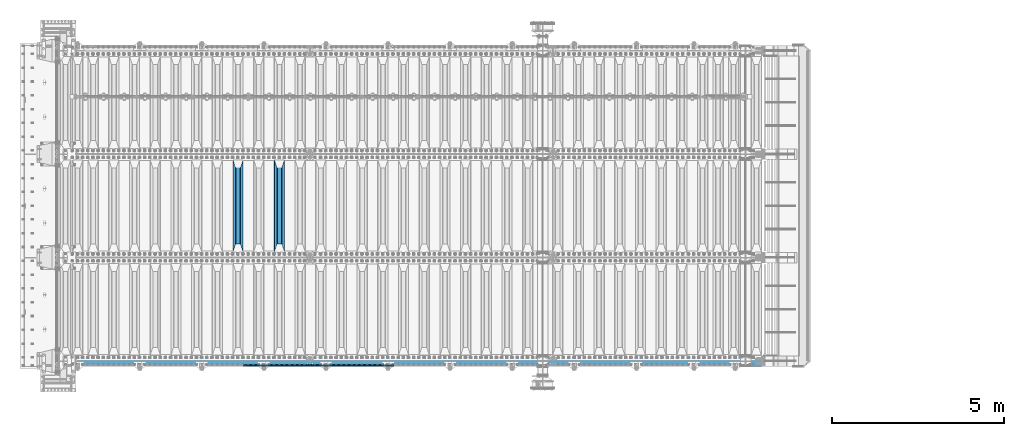
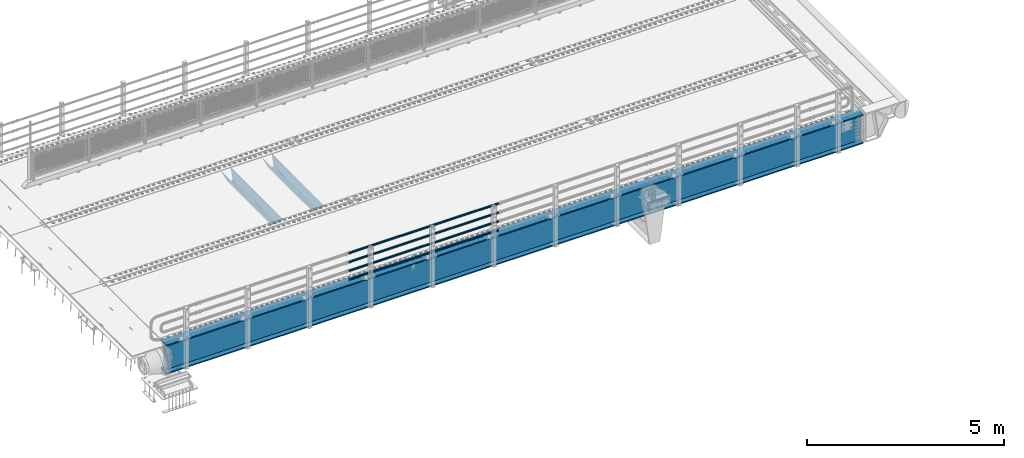
# One storey, part 120 of 270: 7 beams.
"""IFC2X3 building model written with IfcOpenShell, lengths in millimetres."""

from ifc_helpers import new_model, si_unit, frame, origin_with_axes, place, context, subcontext, project, spatial, faceted_brep, material, type_object, element, save


model = new_model("IFC2X3")

# Units and contexts
model_context = context("Model", 3, precision=1e-05, world=origin_with_axes())
body_context = subcontext(model_context, "Body", "Model", "MODEL_VIEW")
ifc_project = project(units=[si_unit("LENGTHUNIT", "METRE", prefix="MILLI"), si_unit("AREAUNIT", "SQUARE_METRE"), si_unit("VOLUMEUNIT", "CUBIC_METRE"), si_unit("MASSUNIT", "GRAM", prefix="KILO"), si_unit("TIMEUNIT", "SECOND"), si_unit("PLANEANGLEUNIT", "RADIAN"), si_unit("SOLIDANGLEUNIT", "STERADIAN"), si_unit("THERMODYNAMICTEMPERATUREUNIT", "DEGREE_CELSIUS"), si_unit("LUMINOUSINTENSITYUNIT", "LUMEN")], contexts=[model_context])

# Site, building, storey
site_placement = place(None, origin_with_axes())
site = spatial("IfcSite", under=ifc_project, at=site_placement, CompositionType="ELEMENT")
building_placement = place(site_placement, origin_with_axes())
building = spatial("IfcBuilding", under=site, at=building_placement, Name="Standard", CompositionType="ELEMENT")
storey_placement = place(building_placement, origin_with_axes())
storey = spatial("IfcBuildingStorey", under=building, at=storey_placement, Name="Undefined", CompositionType="ELEMENT", Elevation=0.0)

# Beams
ifc_material_1 = material()
beam_type_1 = type_object("IfcBeamType", PredefinedType="NOTDEFINED")
beam_1_placement = place(storey_placement, frame((9727.99999999987, -24129.8499999999, 149.849999999726), z_axis=(0.0, 0.0, -1.0), x_axis=(-1.0, 0.0, 0.0)))
element("IfcBeam", 1, at=beam_1_placement, inside=storey, type_object=beam_type_1, material=ifc_material_1, context=body_context, shape_type="Brep", body=[
    faceted_brep([(0.0, -26.5499999999993, 0.0), (0.0, -24.5290015881747, 10.1602451292931), (4384.00249699992, -24.5290015881747, 10.1602451292931), (4384.00249699992, -26.5499999999993, 0.0), (0.0, -18.7736850405036, 18.7736850405028), (4384.00249699992, -18.7736850405036, 18.7736850405028), (0.0, -10.1602451292929, 24.5290015881747), (4384.00249699992, -10.1602451292929, 24.5290015881747), (0.0, 0.0, 26.55), (4384.00249699992, 0.0, 26.55), (0.0, 10.1602451292929, 24.5290015881747), (4384.00249699992, 10.1602451292929, 24.5290015881747), (0.0, 18.7736850405036, 18.7736850405028), (4384.00249699992, 18.7736850405036, 18.7736850405028), (0.0, 24.5290015881747, 10.1602451292931), (4384.00249699992, 24.5290015881747, 10.1602451292931), (0.0, 26.5499999999993, 0.0), (4384.00249699992, 26.5499999999993, 0.0), (0.0, 24.5290015881747, -10.1602451292931), (4384.00249699992, 24.5290015881747, -10.1602451292931), (0.0, 18.7736850405036, -18.7736850405028), (4384.00249699992, 18.7736850405036, -18.7736850405028), (0.0, 10.1602451292929, -24.5290015881747), (4384.00249699992, 10.1602451292929, -24.5290015881747), (0.0, 0.0, -26.55), (4384.00249699992, 0.0, -26.55), (0.0, -10.1602451292929, -24.5290015881747), (4384.00249699992, -10.1602451292929, -24.5290015881747), (0.0, -18.7736850405036, -18.7736850405028), (4384.00249699992, -18.7736850405036, -18.7736850405028), (0.0, -24.5290015881747, -10.1602451292931), (4384.00249699992, -24.5290015881747, -10.1602451292931), (0.0, -30.1499999999996, 0.0), (0.0, -27.8549679052157, -11.5379054858058), (4384.00249699992, -27.8549679052157, -11.5379054858075), (4384.00249699992, -30.1499999999996, 0.0), (0.0, -21.3192694527752, -21.3192694527752), (4384.00249699992, -21.3192694527752, -21.3192694527744), (0.0, -11.5379054858076, -27.8549679052157), (4384.00249699992, -11.5379054858076, -27.8549679052153), (0.0, 0.0, -30.1500000000015), (4384.00249699992, 0.0, -30.15), (0.0, 11.5379054858076, -27.8549679052157), (4384.00249699992, 11.5379054858076, -27.8549679052153), (0.0, 21.3192694527752, -21.3192694527752), (4384.00249699992, 21.3192694527752, -21.3192694527744), (0.0, 27.8549679052157, -11.5379054858058), (4384.00249699992, 27.8549679052157, -11.5379054858074), (0.0, 30.1499999999996, 0.0), (4384.00249699992, 30.1499999999996, 0.0), (0.0, 27.8549679052157, 11.5379054858058), (4384.00249699992, 27.8549679052157, 11.5379054858075), (0.0, 21.3192694527752, 21.3192694527752), (4384.00249699992, 21.3192694527752, 21.3192694527744), (0.0, 11.5379054858076, 27.8549679052157), (4384.00249699992, 11.5379054858076, 27.8549679052153), (0.0, 0.0, 30.1500000000015), (4384.00249699992, 0.0, 30.15), (0.0, -11.5379054858076, 27.8549679052157), (4384.00249699992, -11.5379054858076, 27.8549679052153), (0.0, -21.3192694527752, 21.3192694527752), (4384.00249699992, -21.3192694527752, 21.3192694527744), (0.0, -27.8549679052157, 11.5379054858058), (4384.00249699992, -27.8549679052157, 11.5379054858075)], [[[0, 1, 2, 3]], [[1, 4, 5, 2]], [[4, 6, 7, 5]], [[6, 8, 9, 7]], [[8, 10, 11, 9]], [[10, 12, 13, 11]], [[12, 14, 15, 13]], [[14, 16, 17, 15]], [[16, 18, 19, 17]], [[18, 20, 21, 19]], [[20, 22, 23, 21]], [[22, 24, 25, 23]], [[24, 26, 27, 25]], [[26, 28, 29, 27]], [[28, 30, 31, 29]], [[30, 0, 3, 31]], [[32, 33, 34, 35]], [[33, 36, 37, 34]], [[36, 38, 39, 37]], [[38, 40, 41, 39]], [[40, 42, 43, 41]], [[42, 44, 45, 43]], [[44, 46, 47, 45]], [[46, 48, 49, 47]], [[48, 50, 51, 49]], [[50, 52, 53, 51]], [[52, 54, 55, 53]], [[54, 56, 57, 55]], [[56, 58, 59, 57]], [[58, 60, 61, 59]], [[60, 62, 63, 61]], [[62, 32, 35, 63]], [[37, 39, 41, 43, 45, 47, 49, 51, 53, 55, 57, 59, 61, 63, 35, 34], [5, 7, 9, 11, 13, 15, 17, 19, 21, 23, 25, 27, 29, 31, 3, 2]], [[62, 60, 58, 56, 54, 52, 50, 48, 46, 44, 42, 40, 38, 36, 33, 32], [30, 28, 26, 24, 22, 20, 18, 16, 14, 12, 10, 8, 6, 4, 1, 0]]]),
])
beam_2_placement = place(storey_placement, frame((9727.99999999987, -24129.8499999999, 420.149999999729), z_axis=(0.0, 0.0, -1.0), x_axis=(-1.0, 0.0, 0.0)))
element("IfcBeam", 2, at=beam_2_placement, inside=storey, type_object=beam_type_1, material=ifc_material_1, context=body_context, shape_type="Brep", body=[
    faceted_brep([(0.0, -26.5499999999993, 0.0), (0.0, -24.5290015881747, 10.1602451292931), (4384.00249699992, -24.5290015881747, 10.1602451292931), (4384.00249699992, -26.5499999999993, 0.0), (0.0, -18.7736850405036, 18.7736850405028), (4384.00249699992, -18.7736850405036, 18.7736850405028), (0.0, -10.1602451292929, 24.5290015881747), (4384.00249699992, -10.1602451292929, 24.5290015881747), (0.0, 0.0, 26.55), (4384.00249699992, 0.0, 26.55), (0.0, 10.1602451292929, 24.5290015881747), (4384.00249699992, 10.1602451292929, 24.5290015881747), (0.0, 18.7736850405036, 18.7736850405028), (4384.00249699992, 18.7736850405036, 18.7736850405028), (0.0, 24.5290015881747, 10.1602451292931), (4384.00249699992, 24.5290015881747, 10.1602451292931), (0.0, 26.5499999999993, 0.0), (4384.00249699992, 26.5499999999993, 0.0), (0.0, 24.5290015881747, -10.1602451292931), (4384.00249699992, 24.5290015881747, -10.1602451292931), (0.0, 18.7736850405036, -18.7736850405028), (4384.00249699992, 18.7736850405036, -18.7736850405028), (0.0, 10.1602451292929, -24.5290015881747), (4384.00249699992, 10.1602451292929, -24.5290015881747), (0.0, 0.0, -26.55), (4384.00249699992, 0.0, -26.55), (0.0, -10.1602451292929, -24.5290015881747), (4384.00249699992, -10.1602451292929, -24.5290015881747), (0.0, -18.7736850405036, -18.7736850405028), (4384.00249699992, -18.7736850405036, -18.7736850405028), (0.0, -24.5290015881747, -10.1602451292931), (4384.00249699992, -24.5290015881747, -10.1602451292931), (0.0, -30.1499999999996, 0.0), (0.0, -27.8549679052157, -11.5379054858058), (4384.00249699992, -27.8549679052157, -11.5379054858075), (4384.00249699992, -30.1499999999996, 0.0), (0.0, -21.3192694527752, -21.3192694527752), (4384.00249699992, -21.3192694527752, -21.3192694527744), (0.0, -11.5379054858076, -27.8549679052157), (4384.00249699992, -11.5379054858076, -27.8549679052153), (0.0, 0.0, -30.1500000000015), (4384.00249699992, 0.0, -30.15), (0.0, 11.5379054858076, -27.8549679052157), (4384.00249699992, 11.5379054858076, -27.8549679052153), (0.0, 21.3192694527752, -21.3192694527752), (4384.00249699992, 21.3192694527752, -21.3192694527744), (0.0, 27.8549679052157, -11.5379054858058), (4384.00249699992, 27.8549679052157, -11.5379054858074), (0.0, 30.1499999999996, 0.0), (4384.00249699992, 30.1499999999996, 0.0), (0.0, 27.8549679052157, 11.5379054858058), (4384.00249699992, 27.8549679052157, 11.5379054858075), (0.0, 21.3192694527752, 21.3192694527752), (4384.00249699992, 21.3192694527752, 21.3192694527744), (0.0, 11.5379054858076, 27.8549679052157), (4384.00249699992, 11.5379054858076, 27.8549679052153), (0.0, 0.0, 30.1500000000015), (4384.00249699992, 0.0, 30.15), (0.0, -11.5379054858076, 27.8549679052157), (4384.00249699992, -11.5379054858076, 27.8549679052153), (0.0, -21.3192694527752, 21.3192694527752), (4384.00249699992, -21.3192694527752, 21.3192694527744), (0.0, -27.8549679052157, 11.5379054858058), (4384.00249699992, -27.8549679052157, 11.5379054858075)], [[[0, 1, 2, 3]], [[1, 4, 5, 2]], [[4, 6, 7, 5]], [[6, 8, 9, 7]], [[8, 10, 11, 9]], [[10, 12, 13, 11]], [[12, 14, 15, 13]], [[14, 16, 17, 15]], [[16, 18, 19, 17]], [[18, 20, 21, 19]], [[20, 22, 23, 21]], [[22, 24, 25, 23]], [[24, 26, 27, 25]], [[26, 28, 29, 27]], [[28, 30, 31, 29]], [[30, 0, 3, 31]], [[32, 33, 34, 35]], [[33, 36, 37, 34]], [[36, 38, 39, 37]], [[38, 40, 41, 39]], [[40, 42, 43, 41]], [[42, 44, 45, 43]], [[44, 46, 47, 45]], [[46, 48, 49, 47]], [[48, 50, 51, 49]], [[50, 52, 53, 51]], [[52, 54, 55, 53]], [[54, 56, 57, 55]], [[56, 58, 59, 57]], [[58, 60, 61, 59]], [[60, 62, 63, 61]], [[62, 32, 35, 63]], [[37, 39, 41, 43, 45, 47, 49, 51, 53, 55, 57, 59, 61, 63, 35, 34], [5, 7, 9, 11, 13, 15, 17, 19, 21, 23, 25, 27, 29, 31, 3, 2]], [[62, 60, 58, 56, 54, 52, 50, 48, 46, 44, 42, 40, 38, 36, 33, 32], [30, 28, 26, 24, 22, 20, 18, 16, 14, 12, 10, 8, 6, 4, 1, 0]]]),
])
beam_3_placement = place(storey_placement, frame((9727.99999999987, -24129.8499999999, 969.849999999726), z_axis=(0.0, 0.0, -1.0), x_axis=(-1.0, 0.0, 0.0)))
element("IfcBeam", 3, at=beam_3_placement, inside=storey, type_object=beam_type_1, material=ifc_material_1, context=body_context, shape_type="Brep", body=[
    faceted_brep([(0.0, -26.5499999999993, 0.0), (0.0, -24.5290015881747, 10.1602451292931), (4384.00249699992, -24.5290015881747, 10.1602451292931), (4384.00249699992, -26.5499999999993, 0.0), (0.0, -18.7736850405036, 18.7736850405028), (4384.00249699992, -18.7736850405036, 18.7736850405028), (0.0, -10.1602451292929, 24.5290015881747), (4384.00249699992, -10.1602451292929, 24.5290015881747), (0.0, 0.0, 26.55), (4384.00249699992, 0.0, 26.55), (0.0, 10.1602451292929, 24.5290015881747), (4384.00249699992, 10.1602451292929, 24.5290015881747), (0.0, 18.7736850405036, 18.7736850405028), (4384.00249699992, 18.7736850405036, 18.7736850405028), (0.0, 24.5290015881747, 10.1602451292931), (4384.00249699992, 24.5290015881747, 10.1602451292931), (0.0, 26.5499999999993, 0.0), (4384.00249699992, 26.5499999999993, 0.0), (0.0, 24.5290015881747, -10.1602451292931), (4384.00249699992, 24.5290015881747, -10.1602451292931), (0.0, 18.7736850405036, -18.7736850405028), (4384.00249699992, 18.7736850405036, -18.7736850405028), (0.0, 10.1602451292929, -24.5290015881747), (4384.00249699992, 10.1602451292929, -24.5290015881747), (0.0, 0.0, -26.55), (4384.00249699992, 0.0, -26.55), (0.0, -10.1602451292929, -24.5290015881747), (4384.00249699992, -10.1602451292929, -24.5290015881747), (0.0, -18.7736850405036, -18.7736850405028), (4384.00249699992, -18.7736850405036, -18.7736850405028), (0.0, -24.5290015881747, -10.1602451292931), (4384.00249699992, -24.5290015881747, -10.1602451292931), (0.0, -30.1499999999996, 0.0), (0.0, -27.8549679052157, -11.5379054858058), (4384.00249699992, -27.8549679052157, -11.5379054858075), (4384.00249699992, -30.1499999999996, 0.0), (0.0, -21.3192694527752, -21.3192694527752), (4384.00249699992, -21.3192694527752, -21.3192694527744), (0.0, -11.5379054858076, -27.8549679052157), (4384.00249699992, -11.5379054858076, -27.8549679052153), (0.0, 0.0, -30.1500000000015), (4384.00249699992, 0.0, -30.15), (0.0, 11.5379054858076, -27.8549679052157), (4384.00249699992, 11.5379054858076, -27.8549679052153), (0.0, 21.3192694527752, -21.3192694527752), (4384.00249699992, 21.3192694527752, -21.3192694527744), (0.0, 27.8549679052157, -11.5379054858058), (4384.00249699992, 27.8549679052157, -11.5379054858074), (0.0, 30.1499999999996, 0.0), (4384.00249699992, 30.1499999999996, 0.0), (0.0, 27.8549679052157, 11.5379054858058), (4384.00249699992, 27.8549679052157, 11.5379054858075), (0.0, 21.3192694527752, 21.3192694527752), (4384.00249699992, 21.3192694527752, 21.3192694527744), (0.0, 11.5379054858076, 27.8549679052157), (4384.00249699992, 11.5379054858076, 27.8549679052153), (0.0, 0.0, 30.1500000000015), (4384.00249699992, 0.0, 30.15), (0.0, -11.5379054858076, 27.8549679052157), (4384.00249699992, -11.5379054858076, 27.8549679052153), (0.0, -21.3192694527752, 21.3192694527752), (4384.00249699992, -21.3192694527752, 21.3192694527744), (0.0, -27.8549679052157, 11.5379054858058), (4384.00249699992, -27.8549679052157, 11.5379054858075)], [[[0, 1, 2, 3]], [[1, 4, 5, 2]], [[4, 6, 7, 5]], [[6, 8, 9, 7]], [[8, 10, 11, 9]], [[10, 12, 13, 11]], [[12, 14, 15, 13]], [[14, 16, 17, 15]], [[16, 18, 19, 17]], [[18, 20, 21, 19]], [[20, 22, 23, 21]], [[22, 24, 25, 23]], [[24, 26, 27, 25]], [[26, 28, 29, 27]], [[28, 30, 31, 29]], [[30, 0, 3, 31]], [[32, 33, 34, 35]], [[33, 36, 37, 34]], [[36, 38, 39, 37]], [[38, 40, 41, 39]], [[40, 42, 43, 41]], [[42, 44, 45, 43]], [[44, 46, 47, 45]], [[46, 48, 49, 47]], [[48, 50, 51, 49]], [[50, 52, 53, 51]], [[52, 54, 55, 53]], [[54, 56, 57, 55]], [[56, 58, 59, 57]], [[58, 60, 61, 59]], [[60, 62, 63, 61]], [[62, 32, 35, 63]], [[37, 39, 41, 43, 45, 47, 49, 51, 53, 55, 57, 59, 61, 63, 35, 34], [5, 7, 9, 11, 13, 15, 17, 19, 21, 23, 25, 27, 29, 31, 3, 2]], [[62, 60, 58, 56, 54, 52, 50, 48, 46, 44, 42, 40, 38, 36, 33, 32], [30, 28, 26, 24, 22, 20, 18, 16, 14, 12, 10, 8, 6, 4, 1, 0]]]),
])
beam_4_placement = place(storey_placement, frame((9727.99999999987, -24129.8499999999, 689.849999999726), z_axis=(0.0, 0.0, -1.0), x_axis=(-1.0, 0.0, 0.0)))
element("IfcBeam", 4, at=beam_4_placement, inside=storey, type_object=beam_type_1, material=ifc_material_1, context=body_context, shape_type="Brep", body=[
    faceted_brep([(0.0, -26.5499999999993, 0.0), (0.0, -24.5290015881747, 10.1602451292931), (4384.00249699992, -24.5290015881747, 10.1602451292931), (4384.00249699992, -26.5499999999993, 0.0), (0.0, -18.7736850405036, 18.7736850405028), (4384.00249699992, -18.7736850405036, 18.7736850405028), (0.0, -10.1602451292929, 24.5290015881747), (4384.00249699992, -10.1602451292929, 24.5290015881747), (0.0, 0.0, 26.55), (4384.00249699992, 0.0, 26.55), (0.0, 10.1602451292929, 24.5290015881747), (4384.00249699992, 10.1602451292929, 24.5290015881747), (0.0, 18.7736850405036, 18.7736850405028), (4384.00249699992, 18.7736850405036, 18.7736850405028), (0.0, 24.5290015881747, 10.1602451292931), (4384.00249699992, 24.5290015881747, 10.1602451292931), (0.0, 26.5499999999993, 0.0), (4384.00249699992, 26.5499999999993, 0.0), (0.0, 24.5290015881747, -10.1602451292931), (4384.00249699992, 24.5290015881747, -10.1602451292931), (0.0, 18.7736850405036, -18.7736850405028), (4384.00249699992, 18.7736850405036, -18.7736850405028), (0.0, 10.1602451292929, -24.5290015881747), (4384.00249699992, 10.1602451292929, -24.5290015881747), (0.0, 0.0, -26.55), (4384.00249699992, 0.0, -26.55), (0.0, -10.1602451292929, -24.5290015881747), (4384.00249699992, -10.1602451292929, -24.5290015881747), (0.0, -18.7736850405036, -18.7736850405028), (4384.00249699992, -18.7736850405036, -18.7736850405028), (0.0, -24.5290015881747, -10.1602451292931), (4384.00249699992, -24.5290015881747, -10.1602451292931), (0.0, -30.1499999999996, 0.0), (0.0, -27.8549679052157, -11.5379054858058), (4384.00249699992, -27.8549679052157, -11.5379054858075), (4384.00249699992, -30.1499999999996, 0.0), (0.0, -21.3192694527752, -21.3192694527752), (4384.00249699992, -21.3192694527752, -21.3192694527744), (0.0, -11.5379054858076, -27.8549679052157), (4384.00249699992, -11.5379054858076, -27.8549679052153), (0.0, 0.0, -30.1500000000015), (4384.00249699992, 0.0, -30.15), (0.0, 11.5379054858076, -27.8549679052157), (4384.00249699992, 11.5379054858076, -27.8549679052153), (0.0, 21.3192694527752, -21.3192694527752), (4384.00249699992, 21.3192694527752, -21.3192694527744), (0.0, 27.8549679052157, -11.5379054858058), (4384.00249699992, 27.8549679052157, -11.5379054858074), (0.0, 30.1499999999996, 0.0), (4384.00249699992, 30.1499999999996, 0.0), (0.0, 27.8549679052157, 11.5379054858058), (4384.00249699992, 27.8549679052157, 11.5379054858075), (0.0, 21.3192694527752, 21.3192694527752), (4384.00249699992, 21.3192694527752, 21.3192694527744), (0.0, 11.5379054858076, 27.8549679052157), (4384.00249699992, 11.5379054858076, 27.8549679052153), (0.0, 0.0, 30.1500000000015), (4384.00249699992, 0.0, 30.15), (0.0, -11.5379054858076, 27.8549679052157), (4384.00249699992, -11.5379054858076, 27.8549679052153), (0.0, -21.3192694527752, 21.3192694527752), (4384.00249699992, -21.3192694527752, 21.3192694527744), (0.0, -27.8549679052157, 11.5379054858058), (4384.00249699992, -27.8549679052157, 11.5379054858075)], [[[0, 1, 2, 3]], [[1, 4, 5, 2]], [[4, 6, 7, 5]], [[6, 8, 9, 7]], [[8, 10, 11, 9]], [[10, 12, 13, 11]], [[12, 14, 15, 13]], [[14, 16, 17, 15]], [[16, 18, 19, 17]], [[18, 20, 21, 19]], [[20, 22, 23, 21]], [[22, 24, 25, 23]], [[24, 26, 27, 25]], [[26, 28, 29, 27]], [[28, 30, 31, 29]], [[30, 0, 3, 31]], [[32, 33, 34, 35]], [[33, 36, 37, 34]], [[36, 38, 39, 37]], [[38, 40, 41, 39]], [[40, 42, 43, 41]], [[42, 44, 45, 43]], [[44, 46, 47, 45]], [[46, 48, 49, 47]], [[48, 50, 51, 49]], [[50, 52, 53, 51]], [[52, 54, 55, 53]], [[54, 56, 57, 55]], [[56, 58, 59, 57]], [[58, 60, 61, 59]], [[60, 62, 63, 61]], [[62, 32, 35, 63]], [[37, 39, 41, 43, 45, 47, 49, 51, 53, 55, 57, 59, 61, 63, 35, 34], [5, 7, 9, 11, 13, 15, 17, 19, 21, 23, 25, 27, 29, 31, 3, 2]], [[62, 60, 58, 56, 54, 52, 50, 48, 46, 44, 42, 40, 38, 36, 33, 32], [30, 28, 26, 24, 22, 20, 18, 16, 14, 12, 10, 8, 6, 4, 1, 0]]]),
])
ifc_material_2 = material(Name="STEEL/S355N")
beam_type_2 = type_object("IfcBeamType", PredefinedType="NOTDEFINED")
beam_5_placement = place(storey_placement, frame((6400.0, -20825.0, -115.0), z_axis=(0.0, 0.0, 1.0), x_axis=(0.0, 1.0, 0.0)))
element("IfcBeam", 5, at=beam_5_placement, inside=storey, type_object=beam_type_2, material=ifc_material_2, context=body_context, shape_type="Brep", body=[
    faceted_brep([(0.0, 150.0, 115.0), (0.0, 143.689999999999, 115.0), (2650.00000000297, 143.689999999999, 115.0), (2650.00000000297, 150.0, 115.0), (2650.00000000297, 142.059565218398, 110.000000003096), (2650.00000000297, 148.3695652184, 110.000000003096), (2441.90079219209, -80.1103600731112, -98.0992078077845), (2437.7588105432, -77.5672621345584, -102.241189456673), (2434.06523489747, -74.4080125315522, -105.934765102404), (2430.9108609509, -70.710272125576, -109.089139048974), (2428.37322971128, -66.5649389910068, -111.626770288588), (2426.51472138055, -62.0739139532889, -113.485278619323), (2425.38102192092, -57.3475956567672, -114.618978078955), (2424.99999999987, -52.5021667386536, -115.0), (2424.99999999987, 52.5021667386536, -115.0), (2425.38102192092, 57.3475956567672, -114.618978078955), (2426.51472138055, 62.0739139532889, -113.485278619323), (2428.37322971128, 66.5649389910068, -111.626770288588), (2430.9108609509, 70.710272125576, -109.089139048974), (2434.06523489747, 74.4080125315522, -105.934765102404), (2437.7588105432, 77.5672621345584, -102.241189456673), (2441.90079219209, 80.1103600731112, -98.0992078077846), (2446.38936140511, 81.9747917625791, -93.6106385947584), (2448.2494850041, 76.2713538057251, -91.7505149957729), (2444.62967112263, 74.76777986261, -95.3703288772456), (2441.28936334126, 72.7168944282894, -98.710636658607), (2438.31067330439, 70.1691124903846, -101.689326695487), (2435.76682334747, 67.1870637758839, -104.233176652398), (2433.72034654133, 63.8440531834895, -106.279653458539), (2432.22154950042, 60.222258798236, -107.778450499454), (2431.30727574265, 56.4107117849089, -108.692724257221), (2430.99999999987, 52.5031078186876, -109.0), (2430.99999999987, -52.5031078186876, -109.0), (2431.30727574265, -56.4107117849089, -108.692724257221), (2432.22154950042, -60.222258798236, -107.778450499454), (2433.72034654133, -63.8440531834895, -106.279653458539), (2435.76682334747, -67.1870637758839, -104.233176652398), (2438.31067330438, -70.1691124903846, -101.689326695487), (2441.28936334126, -72.7168944282894, -98.7106366586071), (2444.62967112263, -74.76777986261, -95.3703288772457), (2448.2494850041, -76.2713538057251, -91.7505149957729), (2650.00000000297, -142.059565218398, 110.000000003096), (2650.00000000297, -148.3695652184, 110.000000003096), (2446.38936140511, -81.9747917625791, -93.6106385947584), (2650.00000000297, -143.689999999999, 115.0), (2650.00000000297, -150.0, 115.0), (0.0, -143.689999999999, 115.0), (0.0, -150.0, 115.0), (0.0, -148.369565218261, 110.000000002672), (203.610638597431, -81.9747917625791, -93.6106385947584), (208.099207810457, -80.1103600731112, -98.0992078077845), (212.241189459342, -77.5672621345584, -102.241189456673), (215.934765105078, -74.4080125315522, -105.934765102404), (219.089139051644, -70.710272125576, -109.089139048974), (221.626770291259, -66.5649389910068, -111.626770288588), (223.485278621993, -62.0739139532889, -113.485278619323), (224.618978081628, -57.3475956567672, -114.618978078955), (225.00000000267, -52.5021667386536, -115.0), (225.00000000267, 52.5021667386536, -115.0), (224.618978081628, 57.3475956567672, -114.618978078955), (223.485278621993, 62.0739139532889, -113.485278619323), (221.626770291259, 66.5649389910068, -111.626770288588), (219.089139051644, 70.710272125576, -109.089139048974), (215.934765105078, 74.4080125315522, -105.934765102404), (212.241189459342, 77.5672621345584, -102.241189456673), (208.099207810457, 80.1103600731112, -98.0992078077846), (203.610638597431, 81.9747917625791, -93.6106385947584), (0.0, 148.369565218261, 110.000000002672), (0.0, 142.05956521826, 110.000000002672), (201.750514998446, 76.2713538057251, -91.7505149957729), (205.370328879915, 74.76777986261, -95.3703288772456), (208.710636661279, 72.7168944282894, -98.710636658607), (211.689326698157, 70.1691124903846, -101.689326695487), (214.233176655071, 67.1870637758839, -104.233176652398), (216.27965346121, 63.8440531834895, -106.279653458539), (217.778450502126, 60.222258798236, -107.778450499454), (218.692724259894, 56.4107117849089, -108.692724257221), (219.00000000267, 52.5031078186876, -109.0), (219.00000000267, -52.5031078186876, -109.0), (218.692724259894, -56.4107117849089, -108.692724257221), (217.778450502123, -60.222258798236, -107.778450499454), (216.27965346121, -63.8440531834895, -106.279653458539), (214.233176655071, -67.1870637758839, -104.233176652398), (211.689326698157, -70.1691124903846, -101.689326695487), (208.710636661279, -72.7168944282894, -98.7106366586071), (205.370328879915, -74.76777986261, -95.3703288772457), (201.750514998446, -76.2713538057251, -91.7505149957729), (0.0, -142.05956521826, 110.000000002672)], [[[0, 1, 2, 3]], [[3, 2, 4, 5]], [[6, 7, 8, 9, 10, 11, 12, 13, 14, 15, 16, 17, 18, 19, 20, 21, 22, 5, 4, 23, 24, 25, 26, 27, 28, 29, 30, 31, 32, 33, 34, 35, 36, 37, 38, 39, 40, 41, 42, 43]], [[44, 45, 42, 41]], [[46, 47, 45, 44]], [[43, 42, 45, 47, 48, 49]], [[6, 43, 49, 50]], [[7, 6, 50, 51]], [[8, 7, 51, 52]], [[9, 8, 52, 53]], [[10, 9, 53, 54]], [[11, 10, 54, 55]], [[12, 11, 55, 56]], [[13, 12, 56, 57]], [[14, 13, 57, 58]], [[15, 14, 58, 59]], [[16, 15, 59, 60]], [[17, 16, 60, 61]], [[18, 17, 61, 62]], [[19, 18, 62, 63]], [[20, 19, 63, 64]], [[21, 20, 64, 65]], [[22, 21, 65, 66]], [[0, 3, 5, 22, 66, 67]], [[1, 0, 67, 68]], [[23, 4, 2, 1, 68, 69]], [[24, 23, 69, 70]], [[25, 24, 70, 71]], [[26, 25, 71, 72]], [[27, 26, 72, 73]], [[28, 27, 73, 74]], [[29, 28, 74, 75]], [[30, 29, 75, 76]], [[31, 30, 76, 77]], [[32, 31, 77, 78]], [[33, 32, 78, 79]], [[34, 33, 79, 80]], [[35, 34, 80, 81]], [[36, 35, 81, 82]], [[37, 36, 82, 83]], [[38, 37, 83, 84]], [[39, 38, 84, 85]], [[40, 39, 85, 86]], [[46, 44, 41, 40, 86, 87]], [[47, 46, 87, 48]], [[86, 85, 84, 83, 82, 81, 80, 79, 78, 77, 76, 75, 74, 73, 72, 71, 70, 69, 68, 67, 66, 65, 64, 63, 62, 61, 60, 59, 58, 57, 56, 55, 54, 53, 52, 51, 50, 49, 48, 87]]]),
])
beam_6_placement = place(storey_placement, frame((5200.0, -20825.0, -115.0), z_axis=(0.0, 0.0, 1.0), x_axis=(0.0, 1.0, 0.0)))
element("IfcBeam", 6, at=beam_6_placement, inside=storey, type_object=beam_type_2, material=ifc_material_2, context=body_context, shape_type="Brep", body=[
    faceted_brep([(0.0, 150.0, 115.0), (0.0, 143.689999999999, 115.0), (2650.00000000297, 143.689999999999, 115.0), (2650.00000000297, 150.0, 115.0), (2650.00000000297, 142.059565218398, 110.000000003096), (2650.00000000297, 148.3695652184, 110.000000003096), (2441.90079219209, -80.1103600731112, -98.0992078077845), (2437.7588105432, -77.5672621345584, -102.241189456673), (2434.06523489747, -74.4080125315522, -105.934765102404), (2430.9108609509, -70.710272125576, -109.089139048974), (2428.37322971128, -66.5649389910068, -111.626770288588), (2426.51472138055, -62.0739139532889, -113.485278619323), (2425.38102192092, -57.3475956567672, -114.618978078955), (2424.99999999987, -52.5021667386536, -115.0), (2424.99999999987, 52.5021667386536, -115.0), (2425.38102192092, 57.3475956567672, -114.618978078955), (2426.51472138055, 62.0739139532889, -113.485278619323), (2428.37322971128, 66.5649389910068, -111.626770288588), (2430.9108609509, 70.710272125576, -109.089139048974), (2434.06523489747, 74.4080125315522, -105.934765102404), (2437.7588105432, 77.5672621345584, -102.241189456673), (2441.90079219209, 80.1103600731112, -98.0992078077846), (2446.38936140511, 81.9747917625791, -93.6106385947584), (2448.2494850041, 76.2713538057251, -91.7505149957729), (2444.62967112263, 74.76777986261, -95.3703288772456), (2441.28936334126, 72.7168944282894, -98.710636658607), (2438.31067330439, 70.1691124903846, -101.689326695487), (2435.76682334747, 67.1870637758839, -104.233176652398), (2433.72034654133, 63.8440531834895, -106.279653458539), (2432.22154950042, 60.222258798236, -107.778450499454), (2431.30727574265, 56.4107117849089, -108.692724257221), (2430.99999999987, 52.5031078186876, -109.0), (2430.99999999987, -52.5031078186876, -109.0), (2431.30727574265, -56.4107117849089, -108.692724257221), (2432.22154950042, -60.222258798236, -107.778450499454), (2433.72034654133, -63.8440531834895, -106.279653458539), (2435.76682334747, -67.1870637758839, -104.233176652398), (2438.31067330438, -70.1691124903846, -101.689326695487), (2441.28936334126, -72.7168944282894, -98.7106366586071), (2444.62967112263, -74.76777986261, -95.3703288772457), (2448.2494850041, -76.2713538057251, -91.7505149957729), (2650.00000000297, -142.059565218398, 110.000000003096), (2650.00000000297, -148.3695652184, 110.000000003096), (2446.38936140511, -81.9747917625791, -93.6106385947584), (2650.00000000297, -143.689999999999, 115.0), (2650.00000000297, -150.0, 115.0), (0.0, -143.689999999999, 115.0), (0.0, -150.0, 115.0), (0.0, -148.369565218261, 110.000000002672), (203.610638597431, -81.9747917625791, -93.6106385947584), (208.099207810457, -80.1103600731112, -98.0992078077845), (212.241189459342, -77.5672621345584, -102.241189456673), (215.934765105078, -74.4080125315522, -105.934765102404), (219.089139051644, -70.710272125576, -109.089139048974), (221.626770291259, -66.5649389910068, -111.626770288588), (223.485278621993, -62.0739139532889, -113.485278619323), (224.618978081628, -57.3475956567672, -114.618978078955), (225.00000000267, -52.5021667386536, -115.0), (225.00000000267, 52.5021667386536, -115.0), (224.618978081628, 57.3475956567672, -114.618978078955), (223.485278621993, 62.0739139532889, -113.485278619323), (221.626770291259, 66.5649389910068, -111.626770288588), (219.089139051644, 70.710272125576, -109.089139048974), (215.934765105078, 74.4080125315522, -105.934765102404), (212.241189459342, 77.5672621345584, -102.241189456673), (208.099207810457, 80.1103600731112, -98.0992078077846), (203.610638597431, 81.9747917625791, -93.6106385947584), (0.0, 148.369565218261, 110.000000002672), (0.0, 142.05956521826, 110.000000002672), (201.750514998446, 76.2713538057251, -91.7505149957729), (205.370328879915, 74.76777986261, -95.3703288772456), (208.710636661279, 72.7168944282894, -98.710636658607), (211.689326698157, 70.1691124903846, -101.689326695487), (214.233176655071, 67.1870637758839, -104.233176652398), (216.27965346121, 63.8440531834895, -106.279653458539), (217.778450502126, 60.222258798236, -107.778450499454), (218.692724259894, 56.4107117849089, -108.692724257221), (219.00000000267, 52.5031078186876, -109.0), (219.00000000267, -52.5031078186876, -109.0), (218.692724259894, -56.4107117849089, -108.692724257221), (217.778450502123, -60.222258798236, -107.778450499454), (216.27965346121, -63.8440531834895, -106.279653458539), (214.233176655071, -67.1870637758839, -104.233176652398), (211.689326698157, -70.1691124903846, -101.689326695487), (208.710636661279, -72.7168944282894, -98.7106366586071), (205.370328879915, -74.76777986261, -95.3703288772457), (201.750514998446, -76.2713538057251, -91.7505149957729), (0.0, -142.05956521826, 110.000000002672)], [[[0, 1, 2, 3]], [[3, 2, 4, 5]], [[6, 7, 8, 9, 10, 11, 12, 13, 14, 15, 16, 17, 18, 19, 20, 21, 22, 5, 4, 23, 24, 25, 26, 27, 28, 29, 30, 31, 32, 33, 34, 35, 36, 37, 38, 39, 40, 41, 42, 43]], [[44, 45, 42, 41]], [[46, 47, 45, 44]], [[43, 42, 45, 47, 48, 49]], [[6, 43, 49, 50]], [[7, 6, 50, 51]], [[8, 7, 51, 52]], [[9, 8, 52, 53]], [[10, 9, 53, 54]], [[11, 10, 54, 55]], [[12, 11, 55, 56]], [[13, 12, 56, 57]], [[14, 13, 57, 58]], [[15, 14, 58, 59]], [[16, 15, 59, 60]], [[17, 16, 60, 61]], [[18, 17, 61, 62]], [[19, 18, 62, 63]], [[20, 19, 63, 64]], [[21, 20, 64, 65]], [[22, 21, 65, 66]], [[0, 3, 5, 22, 66, 67]], [[1, 0, 67, 68]], [[23, 4, 2, 1, 68, 69]], [[24, 23, 69, 70]], [[25, 24, 70, 71]], [[26, 25, 71, 72]], [[27, 26, 72, 73]], [[28, 27, 73, 74]], [[29, 28, 74, 75]], [[30, 29, 75, 76]], [[31, 30, 76, 77]], [[32, 31, 77, 78]], [[33, 32, 78, 79]], [[34, 33, 79, 80]], [[35, 34, 80, 81]], [[36, 35, 81, 82]], [[37, 36, 82, 83]], [[38, 37, 83, 84]], [[39, 38, 84, 85]], [[40, 39, 85, 86]], [[46, 44, 41, 40, 86, 87]], [[47, 46, 87, 48]], [[86, 85, 84, 83, 82, 81, 80, 79, 78, 77, 76, 75, 74, 73, 72, 71, 70, 69, 68, 67, 66, 65, 64, 63, 62, 61, 60, 59, 58, 57, 56, 55, 54, 53, 52, 51, 50, 49, 48, 87]]]),
])
beam_type_3 = type_object("IfcBeamType", Name="HEB900", PredefinedType="NOTDEFINED")
beam_7_placement = place(storey_placement, frame((10.0, -24000.0, -450.0), z_axis=(0.0, 0.0, 1.0), x_axis=(1.0, 0.0, 0.0)))
element("IfcBeam", 7, at=beam_7_placement, inside=storey, type_object=beam_type_3, material=ifc_material_2, ObjectType="HEB900", context=body_context, shape_type="Brep", body=[
    faceted_brep([(0.0, 150.0, -450.0), (0.0, 150.0, -415.0), (20380.0, 150.0, -415.0), (20380.0, 150.0, -450.0), (0.0, 9.25, -415.0), (20380.0, 9.25, -415.0), (0.0, 9.25, 415.0), (20380.0, 9.25, 415.0), (0.0, 150.0, 415.0), (20380.0, 150.0, 415.0), (0.0, 150.0, 450.0), (20380.0, 150.0, 450.0), (0.0, -150.0, 450.0), (20380.0, -150.0, 450.0), (0.0, -150.0, 415.0), (20380.0, -150.0, 415.0), (0.0, -9.25, 415.0), (20380.0, -9.25, 415.0), (0.0, -9.25, -415.0), (20380.0, -9.25, -415.0), (0.0, -150.0, -415.0), (20380.0, -150.0, -415.0), (0.0, -150.0, -450.0), (20380.0, -150.0, -450.0)], [[[0, 1, 2, 3]], [[1, 4, 5, 2]], [[4, 6, 7, 5]], [[6, 8, 9, 7]], [[8, 10, 11, 9]], [[10, 12, 13, 11]], [[12, 14, 15, 13]], [[14, 16, 17, 15]], [[16, 18, 19, 17]], [[18, 20, 21, 19]], [[20, 22, 23, 21]], [[22, 0, 3, 23]], [[5, 7, 9, 11, 13, 15, 17, 19, 21, 23, 3, 2]], [[22, 20, 18, 16, 14, 12, 10, 8, 6, 4, 1, 0]]]),
])

save(model, "model.ifc")
